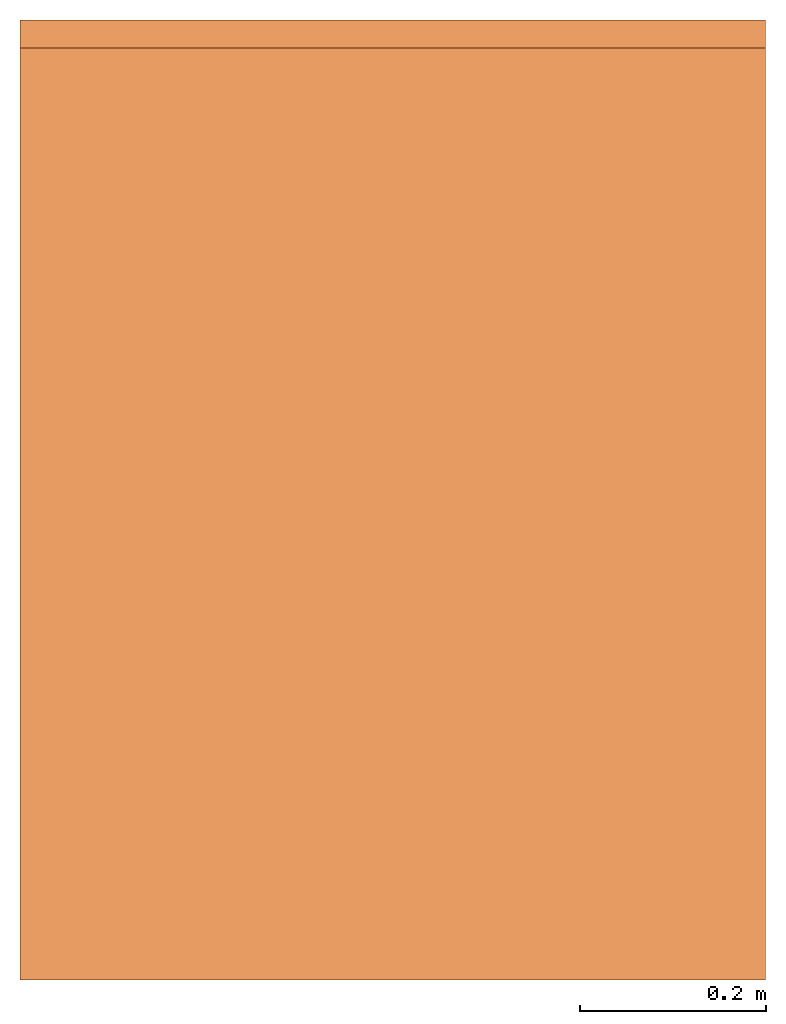
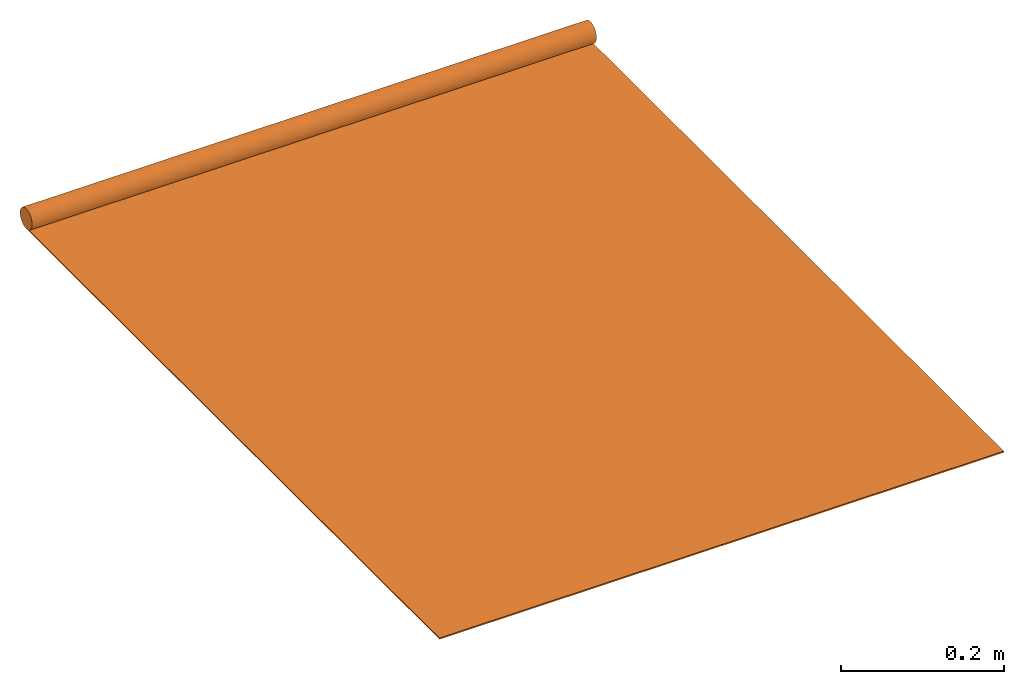
# One storey: 1 proxy.
"""IFC2X3 building model written with IfcOpenShell, lengths in millimetres."""

from ifc_helpers import new_model, entity, si_unit, converted_unit, derived_unit, direction, frame, frame_2d, origin, origin_2d_with_axis, place, context, subcontext, project, spatial, polyline, circle_curve, parameter, trimmed, segment, composite_curve, rectangle, circle, hollow_circle, outline, extrude, source, transform, mapped, material, material_list, element, save


model = new_model("IFC2X3")

# Units and contexts
model_context = context("Model", 3, precision=0.01, world=origin(), true_north=direction((6.12303176911189e-17, 1.0)))
context_of_model = context(None, 3, precision=0.01, world=origin(), true_north=direction((6.12303176911189e-17, 1.0)))
body_context = subcontext(model_context, "Body", "Model", "MODEL_VIEW")
ifc_project = project(units=[si_unit("LENGTHUNIT", "METRE", prefix="MILLI"), si_unit("AREAUNIT", "SQUARE_METRE"), si_unit("VOLUMEUNIT", "CUBIC_METRE"), converted_unit("PLANEANGLEUNIT", "DEGREE", entity("IfcRatioMeasure", 0.0174532925199433), si_unit("PLANEANGLEUNIT", "RADIAN"), dimensions=[0, 0, 0, 0, 0, 0, 0]), si_unit("MASSUNIT", "GRAM", prefix="KILO"), si_unit("TIMEUNIT", "SECOND"), si_unit("FREQUENCYUNIT", "HERTZ"), si_unit("THERMODYNAMICTEMPERATUREUNIT", "DEGREE_CELSIUS"), derived_unit("THERMALTRANSMITTANCEUNIT", [(si_unit("MASSUNIT", "GRAM", prefix="KILO"), 1), (si_unit("THERMODYNAMICTEMPERATUREUNIT", "KELVIN"), -1), (si_unit("TIMEUNIT", "SECOND"), -3)]), derived_unit("VOLUMETRICFLOWRATEUNIT", [(si_unit("LENGTHUNIT", "METRE"), 3), (si_unit("TIMEUNIT", "SECOND"), -1)]), si_unit("ELECTRICCURRENTUNIT", "AMPERE"), si_unit("ELECTRICVOLTAGEUNIT", "VOLT"), si_unit("POWERUNIT", "WATT"), si_unit("FORCEUNIT", "NEWTON", prefix="KILO"), si_unit("ILLUMINANCEUNIT", "LUX"), si_unit("LUMINOUSFLUXUNIT", "LUMEN"), si_unit("LUMINOUSINTENSITYUNIT", "CANDELA"), si_unit("PRESSUREUNIT", "PASCAL")], contexts=[model_context, context_of_model])

# Site, building, storey
site_placement = place(None, origin())
site = spatial("IfcSite", under=ifc_project, at=site_placement, CompositionType="ELEMENT")
building_placement = place(site_placement, origin())
building = spatial("IfcBuilding", under=site, at=building_placement, CompositionType="ELEMENT")
storey_placement = place(building_placement, origin())
storey = spatial("IfcBuildingStorey", under=building, at=storey_placement, Name="Level 0", CompositionType="ELEMENT", Elevation=0.0)

# Proxy
ifc_material_1 = material(Name="Fabric - M-Screen 0702A5")
ifc_material_2 = material(Name="Fabric - M-Screen A5")
ifc_material_3 = material(Name="Aluminum")
ifc_material_list = material_list([ifc_material_1, ifc_material_2, ifc_material_3])
shared_shape = source(origin(), body_context, "Body", "SweptSolid", [
    extrude(hollow_circle(Radius=15.0, WallThickness=2.00000000000003, at=frame_2d((0.0, -2.32647234810202e-14), x_axis=(1.0, 0.0))), frame((-400.0, -15.0, 15.0), z_axis=(1.0, 0.0, 0.0), x_axis=(0.0, 1.0, 0.0)), (0.0, 0.0, 1.0), 800.0),
    extrude(outline(composite_curve([segment(polyline([(-0.400000000000007, -497.106465448021), (0.399999999999993, -497.106465448021)]), True, "CONTINUOUS"), segment(polyline([(0.399999999999993, -497.106465448021), (0.399999999999994, 498.060316162572)]), True, "CONTINUOUS"), segment(trimmed(circle_curve(frame_2d((-13.7999999999968, 502.893534552019), x_axis=(0.0, 1.0)), 15.0), [parameter(243.295147752396)], [parameter(251.203094964933)], True, "PARAMETER"), False, "CONTINUOUS"), segment(polyline([(-0.400000000000007, 496.152614733471), (-0.400000000000007, -497.106465448021)]), True, "CONTINUOUS")], self_intersect=False)), frame((-400.0, -517.893534551988, 1.20000000000902), z_axis=(1.0, 0.0, 0.0), x_axis=(0.0, 0.0, -1.0)), (0.0, 0.0, 1.0), 800.0),
    extrude(outline(composite_curve([segment(polyline([(-498.791695402648, -0.399999999990873), (501.208304597351, -0.399999999990873)]), True, "CONTINUOUS"), segment(trimmed(circle_curve(frame_2d((501.208304597352, 14.6000000000091), x_axis=(1.0, 0.0)), 15.0), [parameter(251.203094965014)], [parameter(270.0)], True, "PARAMETER"), False, "CONTINUOUS"), segment(polyline([(496.375086207944, 0.399999999974459), (-498.791695402648, 0.400000000007287)]), True, "CONTINUOUS"), segment(polyline([(-498.791695402648, 0.400000000007287), (-498.791695402648, -0.399999999990873)]), True, "CONTINUOUS")], self_intersect=False)), frame((-400.0, -516.20830459736, 0.400000000004559), z_axis=(1.0, 0.0, 0.0), x_axis=(0.0, 1.0, 0.0)), (0.0, 0.0, 1.0), 800.0),
    extrude(rectangle(XDim=800.0, YDim=14.9999999999998, at=origin_2d_with_axis()), frame((0.0, -1022.50000000001, 0.0), z_axis=(0.0, 0.0, 1.0), x_axis=(-1.0, 0.0, 0.0)), (0.0, 0.0, 1.0), 2.00000000000493),
    extrude(circle(Radius=13.0, at=frame_2d((0.0, -9.30588939240806e-13), x_axis=(1.0, 0.0))), frame((-400.0, -15.0, 15.0), z_axis=(1.0, 0.0, 0.0), x_axis=(0.0, 1.0, 0.0)), (0.0, 0.0, 1.0), 800.0),
])
proxy_placement = place(storey_placement, frame((-2968.21062984191, 967.792084013913, 0.0)))
element("IfcBuildingElementProxy", 1, at=proxy_placement, inside=storey, material=ifc_material_list, ObjectType="0702A5", CompositionType="ELEMENT", context=body_context, shape_type="MappedRepresentation", body=[
    mapped(shared_shape, transform((0.0, 0.0, 0.0), scale=1.0)),
])

save(model, "model.ifc")
